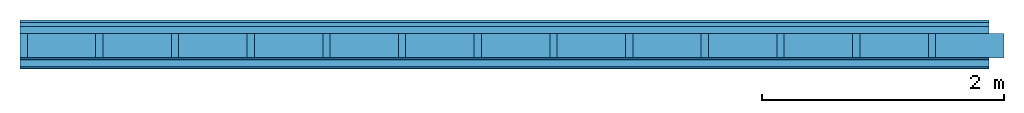
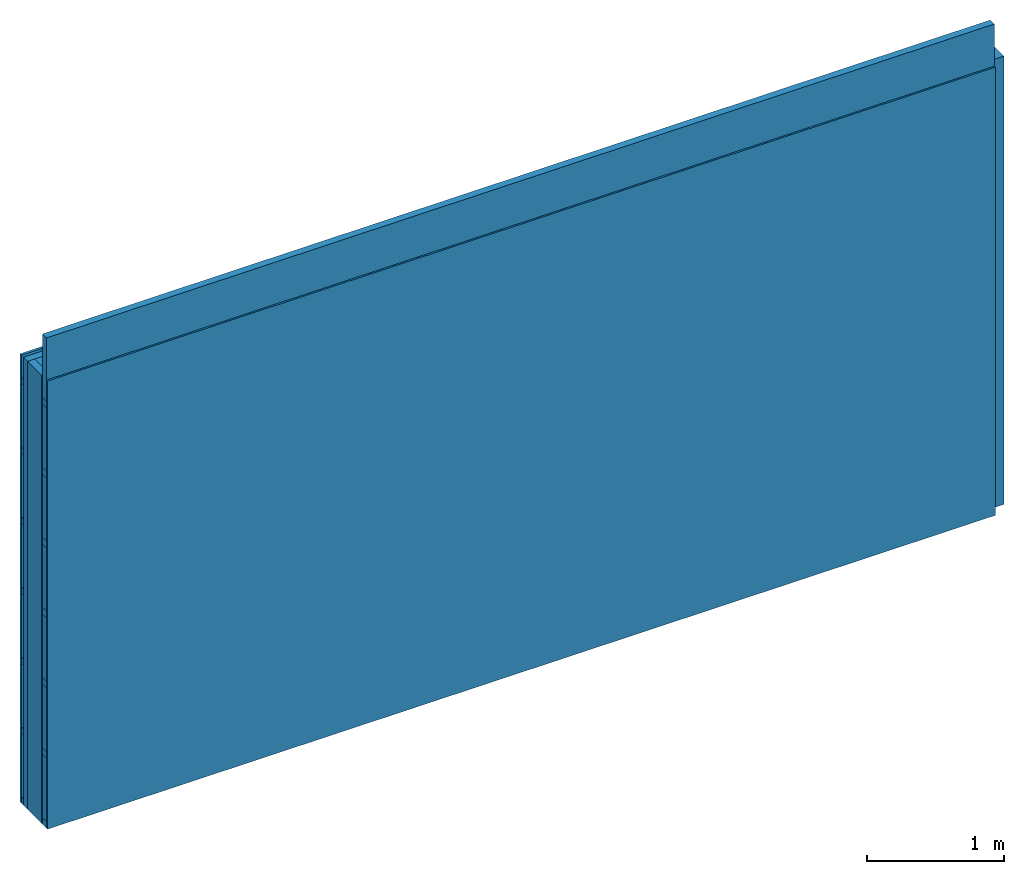
# One storey: 5 members, 4 plates, 1 element without a shape of its own.
"""IFC4 building model written with IfcOpenShell, lengths in metres."""

from ifc_helpers import new_model, si_unit, derived_unit, direction, frame, frame_2d, origin, origin_with_axes, place, context, project, spatial, rectangle, extrude, material, layer, layer_set, type_object, element, aggregate, save


model = new_model("IFC4")

# Units and contexts
plan_context = context("Plan", 3, precision=1e-05, world=origin(), true_north=direction((0.0, 1.0)))
model_context = context("Model", 3, precision=1e-05, world=origin(), true_north=direction((0.0, 1.0)))
ifc_project = project(units=[si_unit("LENGTHUNIT", "METRE"), derived_unit("SOUNDPRESSUREUNIT", [(si_unit("PRESSUREUNIT", "PASCAL", prefix="MICRO"), 0)]), si_unit("ENERGYUNIT", "JOULE", prefix="MEGA"), si_unit("MASSUNIT", "GRAM", prefix="KILO"), derived_unit("THERMALTRANSMITTANCEUNIT", [(si_unit("POWERUNIT", "WATT"), 1), (si_unit("AREAUNIT", "SQUARE_METRE"), -1), (si_unit("THERMODYNAMICTEMPERATUREUNIT", "KELVIN"), -1)]), derived_unit("AREADENSITYUNIT", [(si_unit("MASSUNIT", "GRAM", prefix="KILO"), 1), (si_unit("AREAUNIT", "SQUARE_METRE"), -1)]), derived_unit("USERDEFINED", [(si_unit("ENERGYUNIT", "JOULE", prefix="MEGA"), 1), (si_unit("AREAUNIT", "SQUARE_METRE"), -1)])], contexts=[plan_context, model_context])

# Site, building, storey
site = spatial("IfcSite", under=ifc_project)
building_placement = place(None, origin())
building = spatial("IfcBuilding", under=site, at=building_placement)
storey_placement = place(building_placement, origin())
storey = spatial("IfcBuildingStorey", under=building, at=storey_placement)

# Wall, members, plates
ifc_material_1 = material(Name="Wood cladding horizontal, closed")
ifc_layer_1 = layer(ifc_material_1, 0.022, Name="Cover 1st layer")
ifc_layer_2 = layer(None, 0.03, Name="Battens / profiles (ventilation)")
ifc_material_2 = material(Category="10.009")
ifc_layer_3 = layer(ifc_material_2, 0.06, Name="outside 2nd layer")
ifc_material_3 = material(Name="of the art")
ifc_layer_4 = layer(ifc_material_3, 0.0, Name="Bond")
ifc_layer_5 = layer(None, 0.2, Name="Support")
ifc_layer_6 = layer(ifc_material_3, 0.0, Name="Bond")
ifc_material_4 = material(Category="03.007")
ifc_layer_7 = layer(ifc_material_4, 0.015, Name="1st layer")
ifc_layer_8 = layer(None, 0.06, Name="Battens / profiles")
ifc_layer_9 = layer(ifc_material_4, 0.015, Name="Covering 1st layer")
ifc_material_5 = material(Name="Glued joints")
ifc_layer_10 = layer(ifc_material_5, 0.0, Name="Surface")
ifc_layer_set = layer_set([ifc_layer_1, ifc_layer_2, ifc_layer_3, ifc_layer_4, ifc_layer_5, ifc_layer_6, ifc_layer_7, ifc_layer_8, ifc_layer_9, ifc_layer_10])
wall_type = type_object("IfcWallType", Name="D0265", PredefinedType="NOTDEFINED", material=ifc_layer_set)
wall_placement = place(None, frame((0.0, 0.0, 0.0), z_axis=(0.0, -1.0, 0.0), x_axis=(1.0, 0.0, 0.0)))
wall = element("IfcWall", 1, at=wall_placement, inside=storey, type_object=wall_type, material=ifc_layer_set, Name="Wall #1")
ifc_material_6 = material()
member_1_placement = place(wall_placement, origin())
member_1 = element("IfcMember", 2, at=member_1_placement, material=ifc_material_6, Name="Battens / profiles (ventilation)", context=plan_context, shape_type="SweptSolid", body=[
    extrude(rectangle(XDim=0.05, YDim=0.03, at=frame_2d((0.025, 0.015), x_axis=(1.0, 0.0))), frame((0.0, 0.0, 0.022), z_axis=(1.0, 0.0, 0.0), x_axis=(0.0, 1.0, 0.0)), (0.0, 0.0, 1.0), 8.0),
    extrude(rectangle(XDim=0.05, YDim=0.03, at=frame_2d((0.025, 0.015), x_axis=(1.0, 0.0))), frame((0.0, 0.625, 0.022), z_axis=(1.0, 0.0, 0.0), x_axis=(0.0, 1.0, 0.0)), (0.0, 0.0, 1.0), 8.0),
    extrude(rectangle(XDim=0.05, YDim=0.03, at=frame_2d((0.025, 0.015), x_axis=(1.0, 0.0))), frame((0.0, 1.25, 0.022), z_axis=(1.0, 0.0, 0.0), x_axis=(0.0, 1.0, 0.0)), (0.0, 0.0, 1.0), 8.0),
    extrude(rectangle(XDim=0.05, YDim=0.03, at=frame_2d((0.025, 0.015), x_axis=(1.0, 0.0))), frame((0.0, 1.875, 0.022), z_axis=(1.0, 0.0, 0.0), x_axis=(0.0, 1.0, 0.0)), (0.0, 0.0, 1.0), 8.0),
    extrude(rectangle(XDim=0.05, YDim=0.03, at=frame_2d((0.025, 0.015), x_axis=(1.0, 0.0))), frame((0.0, 2.5, 0.022), z_axis=(1.0, 0.0, 0.0), x_axis=(0.0, 1.0, 0.0)), (0.0, 0.0, 1.0), 8.0),
    extrude(rectangle(XDim=0.05, YDim=0.03, at=frame_2d((0.025, 0.015), x_axis=(1.0, 0.0))), frame((0.0, 3.125, 0.022), z_axis=(1.0, 0.0, 0.0), x_axis=(0.0, 1.0, 0.0)), (0.0, 0.0, 1.0), 8.0),
    extrude(rectangle(XDim=0.05, YDim=0.03, at=frame_2d((0.025, 0.015), x_axis=(1.0, 0.0))), frame((0.0, 3.75, 0.022), z_axis=(1.0, 0.0, 0.0), x_axis=(0.0, 1.0, 0.0)), (0.0, 0.0, 1.0), 8.0),
])
ifc_material_7 = material()
member_2_placement = place(wall_placement, origin())
member_2 = element("IfcMember", 3, at=member_2_placement, material=ifc_material_7, Name="Support", context=plan_context, shape_type="SweptSolid", body=[
    extrude(rectangle(XDim=0.06, YDim=0.2, at=frame_2d((0.03, 0.1), x_axis=(1.0, 0.0))), frame((0.0, 4.0, 0.112), z_axis=(0.0, -1.0, 0.0), x_axis=(1.0, 0.0, 0.0)), (0.0, 0.0, 1.0), 4.0),
    extrude(rectangle(XDim=0.06, YDim=0.2, at=frame_2d((0.03, 0.1), x_axis=(1.0, 0.0))), frame((0.625, 4.0, 0.112), z_axis=(0.0, -1.0, 0.0), x_axis=(1.0, 0.0, 0.0)), (0.0, 0.0, 1.0), 4.0),
    extrude(rectangle(XDim=0.06, YDim=0.2, at=frame_2d((0.03, 0.1), x_axis=(1.0, 0.0))), frame((1.25, 4.0, 0.112), z_axis=(0.0, -1.0, 0.0), x_axis=(1.0, 0.0, 0.0)), (0.0, 0.0, 1.0), 4.0),
    extrude(rectangle(XDim=0.06, YDim=0.2, at=frame_2d((0.03, 0.1), x_axis=(1.0, 0.0))), frame((1.875, 4.0, 0.112), z_axis=(0.0, -1.0, 0.0), x_axis=(1.0, 0.0, 0.0)), (0.0, 0.0, 1.0), 4.0),
    extrude(rectangle(XDim=0.06, YDim=0.2, at=frame_2d((0.03, 0.1), x_axis=(1.0, 0.0))), frame((2.5, 4.0, 0.112), z_axis=(0.0, -1.0, 0.0), x_axis=(1.0, 0.0, 0.0)), (0.0, 0.0, 1.0), 4.0),
    extrude(rectangle(XDim=0.06, YDim=0.2, at=frame_2d((0.03, 0.1), x_axis=(1.0, 0.0))), frame((3.125, 4.0, 0.112), z_axis=(0.0, -1.0, 0.0), x_axis=(1.0, 0.0, 0.0)), (0.0, 0.0, 1.0), 4.0),
    extrude(rectangle(XDim=0.06, YDim=0.2, at=frame_2d((0.03, 0.1), x_axis=(1.0, 0.0))), frame((3.75, 4.0, 0.112), z_axis=(0.0, -1.0, 0.0), x_axis=(1.0, 0.0, 0.0)), (0.0, 0.0, 1.0), 4.0),
    extrude(rectangle(XDim=0.06, YDim=0.2, at=frame_2d((0.03, 0.1), x_axis=(1.0, 0.0))), frame((4.375, 4.0, 0.112), z_axis=(0.0, -1.0, 0.0), x_axis=(1.0, 0.0, 0.0)), (0.0, 0.0, 1.0), 4.0),
    extrude(rectangle(XDim=0.06, YDim=0.2, at=frame_2d((0.03, 0.1), x_axis=(1.0, 0.0))), frame((5.0, 4.0, 0.112), z_axis=(0.0, -1.0, 0.0), x_axis=(1.0, 0.0, 0.0)), (0.0, 0.0, 1.0), 4.0),
    extrude(rectangle(XDim=0.06, YDim=0.2, at=frame_2d((0.03, 0.1), x_axis=(1.0, 0.0))), frame((5.625, 4.0, 0.112), z_axis=(0.0, -1.0, 0.0), x_axis=(1.0, 0.0, 0.0)), (0.0, 0.0, 1.0), 4.0),
    extrude(rectangle(XDim=0.06, YDim=0.2, at=frame_2d((0.03, 0.1), x_axis=(1.0, 0.0))), frame((6.25, 4.0, 0.112), z_axis=(0.0, -1.0, 0.0), x_axis=(1.0, 0.0, 0.0)), (0.0, 0.0, 1.0), 4.0),
    extrude(rectangle(XDim=0.06, YDim=0.2, at=frame_2d((0.03, 0.1), x_axis=(1.0, 0.0))), frame((6.875, 4.0, 0.112), z_axis=(0.0, -1.0, 0.0), x_axis=(1.0, 0.0, 0.0)), (0.0, 0.0, 1.0), 4.0),
    extrude(rectangle(XDim=0.06, YDim=0.2, at=frame_2d((0.03, 0.1), x_axis=(1.0, 0.0))), frame((7.5, 4.0, 0.112), z_axis=(0.0, -1.0, 0.0), x_axis=(1.0, 0.0, 0.0)), (0.0, 0.0, 1.0), 4.0),
])
ifc_material_8 = material()
member_3_placement = place(wall_placement, origin())
member_3 = element("IfcMember", 4, at=member_3_placement, material=ifc_material_8, Name="Cavity", context=plan_context, shape_type="SweptSolid", body=[
    extrude(rectangle(XDim=0.565, YDim=0.2, at=frame_2d((0.2825, 0.1), x_axis=(1.0, 0.0))), frame((0.06, 4.0, 0.112), z_axis=(0.0, -1.0, 0.0), x_axis=(1.0, 0.0, 0.0)), (0.0, 0.0, 1.0), 4.0),
    extrude(rectangle(XDim=0.565, YDim=0.2, at=frame_2d((0.2825, 0.1), x_axis=(1.0, 0.0))), frame((0.685, 4.0, 0.112), z_axis=(0.0, -1.0, 0.0), x_axis=(1.0, 0.0, 0.0)), (0.0, 0.0, 1.0), 4.0),
    extrude(rectangle(XDim=0.565, YDim=0.2, at=frame_2d((0.2825, 0.1), x_axis=(1.0, 0.0))), frame((1.31, 4.0, 0.112), z_axis=(0.0, -1.0, 0.0), x_axis=(1.0, 0.0, 0.0)), (0.0, 0.0, 1.0), 4.0),
    extrude(rectangle(XDim=0.565, YDim=0.2, at=frame_2d((0.2825, 0.1), x_axis=(1.0, 0.0))), frame((1.935, 4.0, 0.112), z_axis=(0.0, -1.0, 0.0), x_axis=(1.0, 0.0, 0.0)), (0.0, 0.0, 1.0), 4.0),
    extrude(rectangle(XDim=0.565, YDim=0.2, at=frame_2d((0.2825, 0.1), x_axis=(1.0, 0.0))), frame((2.56, 4.0, 0.112), z_axis=(0.0, -1.0, 0.0), x_axis=(1.0, 0.0, 0.0)), (0.0, 0.0, 1.0), 4.0),
    extrude(rectangle(XDim=0.565, YDim=0.2, at=frame_2d((0.2825, 0.1), x_axis=(1.0, 0.0))), frame((3.185, 4.0, 0.112), z_axis=(0.0, -1.0, 0.0), x_axis=(1.0, 0.0, 0.0)), (0.0, 0.0, 1.0), 4.0),
    extrude(rectangle(XDim=0.565, YDim=0.2, at=frame_2d((0.2825, 0.1), x_axis=(1.0, 0.0))), frame((3.81, 4.0, 0.112), z_axis=(0.0, -1.0, 0.0), x_axis=(1.0, 0.0, 0.0)), (0.0, 0.0, 1.0), 4.0),
    extrude(rectangle(XDim=0.565, YDim=0.2, at=frame_2d((0.2825, 0.1), x_axis=(1.0, 0.0))), frame((4.435, 4.0, 0.112), z_axis=(0.0, -1.0, 0.0), x_axis=(1.0, 0.0, 0.0)), (0.0, 0.0, 1.0), 4.0),
    extrude(rectangle(XDim=0.565, YDim=0.2, at=frame_2d((0.2825, 0.1), x_axis=(1.0, 0.0))), frame((5.06, 4.0, 0.112), z_axis=(0.0, -1.0, 0.0), x_axis=(1.0, 0.0, 0.0)), (0.0, 0.0, 1.0), 4.0),
    extrude(rectangle(XDim=0.565, YDim=0.2, at=frame_2d((0.2825, 0.1), x_axis=(1.0, 0.0))), frame((5.685, 4.0, 0.112), z_axis=(0.0, -1.0, 0.0), x_axis=(1.0, 0.0, 0.0)), (0.0, 0.0, 1.0), 4.0),
    extrude(rectangle(XDim=0.565, YDim=0.2, at=frame_2d((0.2825, 0.1), x_axis=(1.0, 0.0))), frame((6.31, 4.0, 0.112), z_axis=(0.0, -1.0, 0.0), x_axis=(1.0, 0.0, 0.0)), (0.0, 0.0, 1.0), 4.0),
    extrude(rectangle(XDim=0.565, YDim=0.2, at=frame_2d((0.2825, 0.1), x_axis=(1.0, 0.0))), frame((6.935, 4.0, 0.112), z_axis=(0.0, -1.0, 0.0), x_axis=(1.0, 0.0, 0.0)), (0.0, 0.0, 1.0), 4.0),
    extrude(rectangle(XDim=0.565, YDim=0.2, at=frame_2d((0.2825, 0.1), x_axis=(1.0, 0.0))), frame((7.56, 4.0, 0.112), z_axis=(0.0, -1.0, 0.0), x_axis=(1.0, 0.0, 0.0)), (0.0, 0.0, 1.0), 4.0),
])
ifc_material_9 = material()
member_4_placement = place(wall_placement, origin())
member_4 = element("IfcMember", 5, at=member_4_placement, material=ifc_material_9, Name="Battens / profiles", context=plan_context, shape_type="SweptSolid", body=[
    extrude(rectangle(XDim=0.06, YDim=0.06, at=frame_2d((0.03, 0.03), x_axis=(1.0, 0.0))), frame((0.0, 0.0, 0.327), z_axis=(1.0, 0.0, 0.0), x_axis=(0.0, 1.0, 0.0)), (0.0, 0.0, 1.0), 8.0),
    extrude(rectangle(XDim=0.06, YDim=0.06, at=frame_2d((0.03, 0.03), x_axis=(1.0, 0.0))), frame((0.0, 0.625, 0.327), z_axis=(1.0, 0.0, 0.0), x_axis=(0.0, 1.0, 0.0)), (0.0, 0.0, 1.0), 8.0),
    extrude(rectangle(XDim=0.06, YDim=0.06, at=frame_2d((0.03, 0.03), x_axis=(1.0, 0.0))), frame((0.0, 1.25, 0.327), z_axis=(1.0, 0.0, 0.0), x_axis=(0.0, 1.0, 0.0)), (0.0, 0.0, 1.0), 8.0),
    extrude(rectangle(XDim=0.06, YDim=0.06, at=frame_2d((0.03, 0.03), x_axis=(1.0, 0.0))), frame((0.0, 1.875, 0.327), z_axis=(1.0, 0.0, 0.0), x_axis=(0.0, 1.0, 0.0)), (0.0, 0.0, 1.0), 8.0),
    extrude(rectangle(XDim=0.06, YDim=0.06, at=frame_2d((0.03, 0.03), x_axis=(1.0, 0.0))), frame((0.0, 2.5, 0.327), z_axis=(1.0, 0.0, 0.0), x_axis=(0.0, 1.0, 0.0)), (0.0, 0.0, 1.0), 8.0),
    extrude(rectangle(XDim=0.06, YDim=0.06, at=frame_2d((0.03, 0.03), x_axis=(1.0, 0.0))), frame((0.0, 3.125, 0.327), z_axis=(1.0, 0.0, 0.0), x_axis=(0.0, 1.0, 0.0)), (0.0, 0.0, 1.0), 8.0),
    extrude(rectangle(XDim=0.06, YDim=0.06, at=frame_2d((0.03, 0.03), x_axis=(1.0, 0.0))), frame((0.0, 3.75, 0.327), z_axis=(1.0, 0.0, 0.0), x_axis=(0.0, 1.0, 0.0)), (0.0, 0.0, 1.0), 8.0),
])
member_5_placement = place(wall_placement, origin())
member_5 = element("IfcMember", 6, at=member_5_placement, material=ifc_material_8, Name="Cavity", context=plan_context, shape_type="SweptSolid", body=[
    extrude(rectangle(XDim=0.565, YDim=0.06, at=frame_2d((0.2825, 0.03), x_axis=(1.0, 0.0))), frame((0.0, 0.06, 0.327), z_axis=(1.0, 0.0, 0.0), x_axis=(0.0, 1.0, 0.0)), (0.0, 0.0, 1.0), 8.0),
    extrude(rectangle(XDim=0.565, YDim=0.06, at=frame_2d((0.2825, 0.03), x_axis=(1.0, 0.0))), frame((0.0, 0.685, 0.327), z_axis=(1.0, 0.0, 0.0), x_axis=(0.0, 1.0, 0.0)), (0.0, 0.0, 1.0), 8.0),
    extrude(rectangle(XDim=0.565, YDim=0.06, at=frame_2d((0.2825, 0.03), x_axis=(1.0, 0.0))), frame((0.0, 1.31, 0.327), z_axis=(1.0, 0.0, 0.0), x_axis=(0.0, 1.0, 0.0)), (0.0, 0.0, 1.0), 8.0),
    extrude(rectangle(XDim=0.565, YDim=0.06, at=frame_2d((0.2825, 0.03), x_axis=(1.0, 0.0))), frame((0.0, 1.935, 0.327), z_axis=(1.0, 0.0, 0.0), x_axis=(0.0, 1.0, 0.0)), (0.0, 0.0, 1.0), 8.0),
    extrude(rectangle(XDim=0.565, YDim=0.06, at=frame_2d((0.2825, 0.03), x_axis=(1.0, 0.0))), frame((0.0, 2.56, 0.327), z_axis=(1.0, 0.0, 0.0), x_axis=(0.0, 1.0, 0.0)), (0.0, 0.0, 1.0), 8.0),
    extrude(rectangle(XDim=0.565, YDim=0.06, at=frame_2d((0.2825, 0.03), x_axis=(1.0, 0.0))), frame((0.0, 3.185, 0.327), z_axis=(1.0, 0.0, 0.0), x_axis=(0.0, 1.0, 0.0)), (0.0, 0.0, 1.0), 8.0),
    extrude(rectangle(XDim=0.565, YDim=0.06, at=frame_2d((0.2825, 0.03), x_axis=(1.0, 0.0))), frame((0.0, 3.81, 0.327), z_axis=(1.0, 0.0, 0.0), x_axis=(0.0, 1.0, 0.0)), (0.0, 0.0, 1.0), 8.0),
])
plate_1_placement = place(wall_placement, origin())
plate_1 = element("IfcPlate", 7, at=plate_1_placement, material=ifc_material_1, Name="Cover 1st layer", context=plan_context, shape_type="SweptSolid", body=[
    extrude(rectangle(XDim=8.0, YDim=4.0, at=frame_2d((4.0, 2.0), x_axis=(1.0, 0.0))), origin_with_axes(), (0.0, 0.0, 1.0), 0.022),
])
plate_2_placement = place(wall_placement, origin())
plate_2 = element("IfcPlate", 8, at=plate_2_placement, material=ifc_material_2, Name="outside 2nd layer", context=plan_context, shape_type="SweptSolid", body=[
    extrude(rectangle(XDim=8.0, YDim=4.0, at=frame_2d((4.0, 2.0), x_axis=(1.0, 0.0))), frame((0.0, 0.0, 0.052), z_axis=(0.0, 0.0, 1.0), x_axis=(1.0, 0.0, 0.0)), (0.0, 0.0, 1.0), 0.06),
])
plate_3_placement = place(wall_placement, origin())
plate_3 = element("IfcPlate", 9, at=plate_3_placement, material=ifc_material_4, Name="1st layer", context=plan_context, shape_type="SweptSolid", body=[
    extrude(rectangle(XDim=8.0, YDim=4.0, at=frame_2d((4.0, 2.0), x_axis=(1.0, 0.0))), frame((0.0, 0.0, 0.312), z_axis=(0.0, 0.0, 1.0), x_axis=(1.0, 0.0, 0.0)), (0.0, 0.0, 1.0), 0.015),
])
plate_4_placement = place(wall_placement, origin())
plate_4 = element("IfcPlate", 10, at=plate_4_placement, material=ifc_material_4, Name="Covering 1st layer", context=plan_context, shape_type="SweptSolid", body=[
    extrude(rectangle(XDim=8.0, YDim=4.0, at=frame_2d((4.0, 2.0), x_axis=(1.0, 0.0))), frame((0.0, 0.0, 0.387), z_axis=(0.0, 0.0, 1.0), x_axis=(1.0, 0.0, 0.0)), (0.0, 0.0, 1.0), 0.015),
])
aggregate(wall, [plate_1, member_1, plate_2, member_2, member_3, plate_3, member_4, member_5, plate_4])

save(model, "model.ifc")
